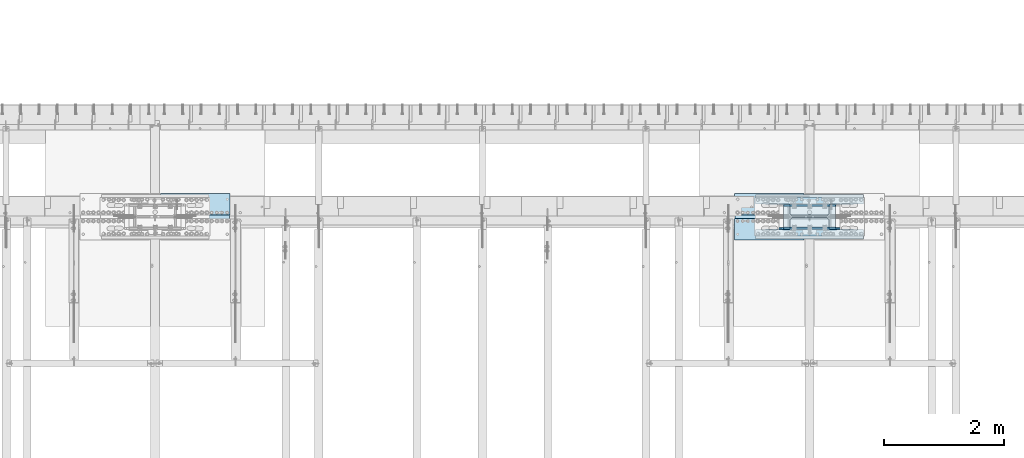
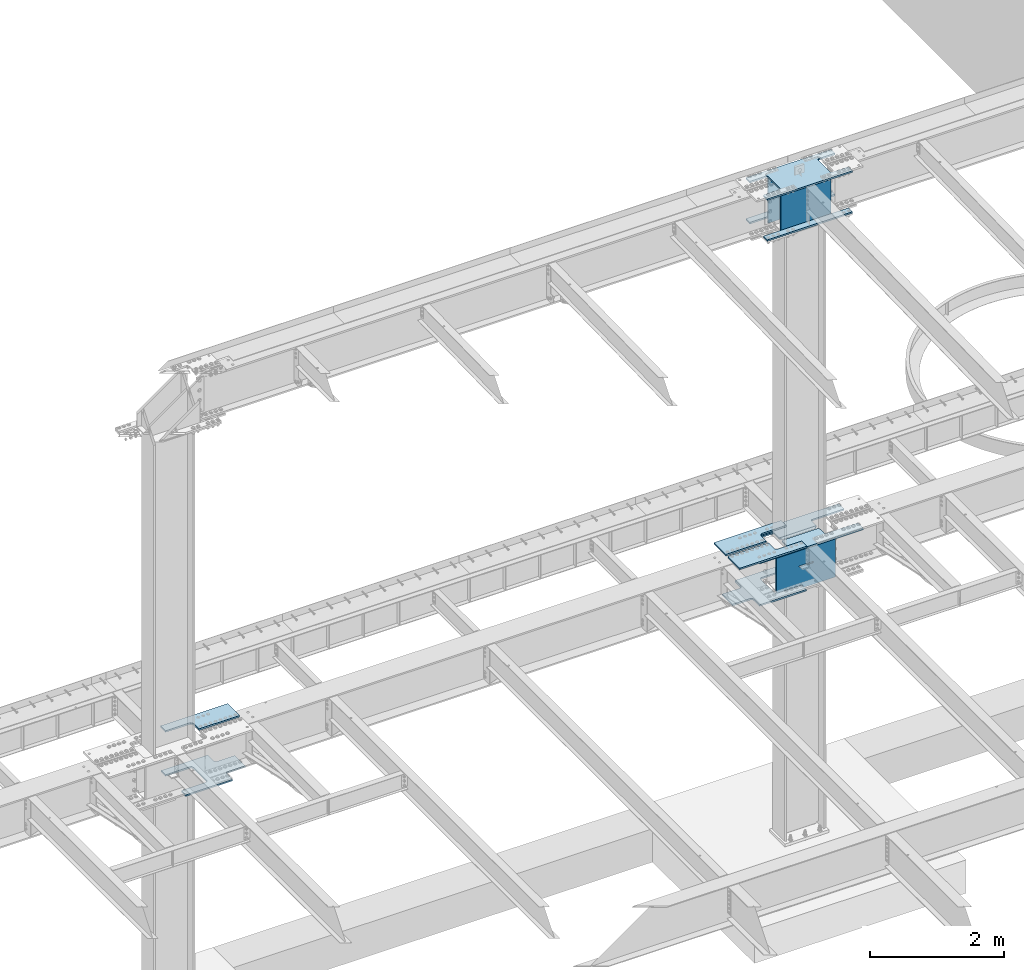
# One storey, part 1421 of 1763: 13 plates, 6 elements without a shape of their own.
"""IFC2X3 building model written with IfcOpenShell, lengths in millimetres."""

import ifcopenshell
import ifcopenshell.guid

model = None  # the IFC model being written
_history = None  # IfcOwnerHistory: only IFC2X3 demands one
_inside = {}  # id of a spatial element -> (the spatial element, [elements in it])
_under = {}  # id of a project, library or spatial element -> (it, [spatial elements below it])
_declared = {}  # id of a project -> (the project, [libraries it declares])
_typed = {}  # id of a type object -> (the type object, [elements of that type])
_made_of = {}  # id of a material, layer set ... -> (it, [elements and type objects made of it])


def new_model(schema):
    """Start an empty IFC model of exactly this schema.

    Asked for "IFC4X3", IfcOpenShell would pick the latest addendum, in which some entities
    have other attributes; the version numbers below select the first issue.
    IFC2X3 requires an IfcOwnerHistory on every rooted entity: one is made here for all.
    """
    global model, _history
    if schema == "IFC4X3":
        model = ifcopenshell.file(schema_version=(4, 3, 0, 0))
    else:
        model = ifcopenshell.file(schema=schema)
    _inside.clear()
    _under.clear()
    _declared.clear()
    _typed.clear()
    _made_of.clear()
    _history = None
    if model.schema == "IFC2X3":
        org = make("IfcOrganization", Name="unknown")
        user = make(
            "IfcPersonAndOrganization",
            ThePerson=make("IfcPerson", FamilyName="unknown"),
            TheOrganization=org,
        )
        app = make(
            "IfcApplication",
            ApplicationDeveloper=org,
            Version="unknown",
            ApplicationFullName="unknown",
            ApplicationIdentifier="unknown",
        )
        _history = make(
            "IfcOwnerHistory",
            OwningUser=user,
            OwningApplication=app,
            ChangeAction="ADDED",
            CreationDate=0,
        )
    return model


def make(cls, **values):
    """One entity of the class cls with the attributes given. An attribute that is None is left unset."""
    return model.create_entity(
        cls, **{name: value for name, value in values.items() if value is not None}
    )


def rooted(cls, **values):
    """An entity with a GlobalId (a new one), such as an element, a storey or a relation."""
    return make(cls, GlobalId=ifcopenshell.guid.new(), OwnerHistory=_history, **values)


def si_unit(unit_type, name, prefix=None):
    """IfcSIUnit, for example si_unit("LENGTHUNIT", "METRE", prefix="MILLI")."""
    return make("IfcSIUnit", UnitType=unit_type, Prefix=prefix, Name=name)


def assignment(units):
    """IfcUnitAssignment: the units of a project."""
    return None if units is None else make("IfcUnitAssignment", Units=units)


def point(xyz):
    """IfcCartesianPoint."""
    return None if xyz is None else make("IfcCartesianPoint", Coordinates=xyz)


def direction(xyz):
    """IfcDirection."""
    return None if xyz is None else make("IfcDirection", DirectionRatios=xyz)


def frame(location, z_axis=None, x_axis=None):
    """IfcAxis2Placement3D, a coordinate frame: its origin and axes. An axis left out is left unset."""
    return make(
        "IfcAxis2Placement3D",
        Location=point(location),
        Axis=direction(z_axis),
        RefDirection=direction(x_axis),
    )


def origin_with_axes():
    """The frame at (0, 0, 0) with the z axis (0, 0, 1) and the x axis (1, 0, 0) written out."""
    return frame((0.0, 0.0, 0.0), z_axis=(0.0, 0.0, 1.0), x_axis=(1.0, 0.0, 0.0))


def place(relative_to, where):
    """IfcLocalPlacement: puts the frame where relative to a parent placement (None: the world)."""
    return make(
        "IfcLocalPlacement", PlacementRelTo=relative_to, RelativePlacement=where
    )


def context(
    kind, dimensions, precision=None, world=None, true_north=None, identifier=None
):
    """IfcGeometricRepresentationContext, for example the 3D "Model" context."""
    return make(
        "IfcGeometricRepresentationContext",
        ContextIdentifier=identifier,
        ContextType=kind,
        CoordinateSpaceDimension=dimensions,
        Precision=precision,
        WorldCoordinateSystem=world,
        TrueNorth=true_north,
    )


def subcontext(parent, identifier, kind, view, scale=None):
    """IfcGeometricRepresentationSubContext, for example "Body" below "Model"."""
    return make(
        "IfcGeometricRepresentationSubContext",
        ContextIdentifier=identifier,
        ContextType=kind,
        ParentContext=parent,
        TargetScale=scale,
        TargetView=view,
    )


def project(units=None, contexts=None):
    """IfcProject with its units and contexts."""
    return rooted(
        "IfcProject",
        Name="project",
        RepresentationContexts=contexts,
        UnitsInContext=assignment(units),
    )


def spatial(cls, under=None, at=None, **own):
    """A site, building, storey or space (cls), placed at a placement, below another one or the project."""
    s = rooted(cls, ObjectPlacement=at, **own)
    if under is not None:
        _under.setdefault(under.id(), (under, []))[1].append(s)
    return s


def faces_of(points, faces, orient=None, outer=None):
    """IfcFace entities. A face is a list of loops; a loop is a list of indices into points, from 0.

    orient and outer hold one flag for each loop. By default every Orientation is true, the
    first loop of a face is its IfcFaceOuterBound and the others are IfcFaceBound.
    """
    made = []
    for i, loops in enumerate(faces):
        bounds = []
        for j, loop in enumerate(loops):
            is_outer = j == 0 if outer is None else outer[i][j]
            bounds.append(
                make(
                    "IfcFaceOuterBound" if is_outer else "IfcFaceBound",
                    Bound=make("IfcPolyLoop", Polygon=[points[k] for k in loop]),
                    Orientation=True if orient is None else orient[i][j],
                )
            )
        made.append(make("IfcFace", Bounds=bounds))
    return made


def faceted_brep(points, faces, orient=None, outer=None, voids=None):
    """IfcFacetedBrep: a solid bounded by flat faces; with voids (closed shells), ...WithVoids."""
    shared = [point(p) for p in points]
    hull = make("IfcClosedShell", CfsFaces=faces_of(shared, faces, orient, outer))
    if voids is None:
        return make("IfcFacetedBrep", Outer=hull)
    return make(
        "IfcFacetedBrepWithVoids",
        Outer=hull,
        Voids=[
            make(cls, CfsFaces=faces_of(shared, fs, o, b)) for cls, fs, o, b in voids
        ],
    )


def shape(context_of_items, identifier, shape_type, items):
    """IfcShapeRepresentation: the items that make up one representation, for example the "Body"."""
    return make(
        "IfcShapeRepresentation",
        ContextOfItems=context_of_items,
        RepresentationIdentifier=identifier,
        RepresentationType=shape_type,
        Items=items,
    )


def material(Name=None, Category=None):
    """IfcMaterial."""
    return make("IfcMaterial", Name=Name, Category=Category)


def made_of(thing, what):
    """Note that an element or type object is made of a material, layer set ...; save() writes the relation."""
    if what is not None:
        _made_of.setdefault(what.id(), (what, []))[1].append(thing)
    return thing


def type_object(cls, material=None, **own):
    """A type object (cls), such as IfcWallType, which elements share."""
    return made_of(rooted(cls, **own), material)


def element(
    cls,
    number,
    at=None,
    inside=None,
    cuts=None,
    type_object=None,
    material=None,
    context=None,
    identifier="Body",
    shape_type=None,
    held_by="IfcProductDefinitionShape",
    body=None,
    shapes=None,
    **own,
):
    """One element of the class cls, such as IfcWall. Its Tag is "e" and its number.

    at: its placement. inside: the storey or other place that contains it. cuts: it is an
    opening in that element (IfcRelVoidsElement). A single representation is given by context,
    identifier, shape_type and body (its items); several are given by shapes. held_by: the class
    of the entity that holds the representations. save() writes the other relations.
    """
    e = rooted(cls, Tag="e%d" % number, ObjectPlacement=at, **own)
    if body is not None:
        shapes = [shape(context, identifier, shape_type, body)]
    if shapes is not None:
        e.Representation = make(held_by, Representations=shapes)
    if inside is not None:
        _inside.setdefault(inside.id(), (inside, []))[1].append(e)
    if cuts is not None:
        rooted(
            "IfcRelVoidsElement", RelatingBuildingElement=cuts, RelatedOpeningElement=e
        )
    if type_object is not None:
        _typed.setdefault(type_object.id(), (type_object, []))[1].append(e)
    return made_of(e, material)


def aggregate(whole, parts):
    """IfcRelAggregates: a whole, such as a stair, and the parts it consists of."""
    return rooted("IfcRelAggregates", RelatingObject=whole, RelatedObjects=parts)


def save(model, path):
    """Write the relations noted so far, then the file.

    IfcRelAggregates (storeys below a building ...), IfcRelContainedInSpatialStructure (elements
    in a storey), IfcRelDefinesByType, IfcRelAssociatesMaterial and IfcRelDeclares: one each for
    every whole, place, type object, material and project.
    """
    for whole, parts in _under.values():
        aggregate(whole, parts)
    for where, things in _inside.values():
        rooted(
            "IfcRelContainedInSpatialStructure",
            RelatedElements=things,
            RelatingStructure=where,
        )
    for kind, things in _typed.values():
        rooted("IfcRelDefinesByType", RelatedObjects=things, RelatingType=kind)
    for what, things in _made_of.values():
        rooted("IfcRelAssociatesMaterial", RelatedObjects=things, RelatingMaterial=what)
    for by, libraries in _declared.values():
        rooted("IfcRelDeclares", RelatingContext=by, RelatedDefinitions=libraries)
    model.write(path)


model = new_model("IFC2X3")

# Units and contexts
model_context = context("Model", 3, precision=1e-05, world=origin_with_axes())
body_context = subcontext(model_context, "Body", "Model", "MODEL_VIEW")
ifc_project = project(units=[si_unit("LENGTHUNIT", "METRE", prefix="MILLI"), si_unit("AREAUNIT", "SQUARE_METRE"), si_unit("VOLUMEUNIT", "CUBIC_METRE"), si_unit("MASSUNIT", "GRAM", prefix="KILO"), si_unit("TIMEUNIT", "SECOND"), si_unit("PLANEANGLEUNIT", "RADIAN"), si_unit("SOLIDANGLEUNIT", "STERADIAN"), si_unit("THERMODYNAMICTEMPERATUREUNIT", "DEGREE_CELSIUS"), si_unit("LUMINOUSINTENSITYUNIT", "LUMEN")], contexts=[model_context])

# Site, building, storey
site_placement = place(None, origin_with_axes())
site = spatial("IfcSite", under=ifc_project, at=site_placement, CompositionType="ELEMENT")
building_placement = place(site_placement, origin_with_axes())
building = spatial("IfcBuilding", under=site, at=building_placement, Name="Undefined", CompositionType="ELEMENT")
storey_placement = place(building_placement, origin_with_axes())
storey = spatial("IfcBuildingStorey", under=building, at=storey_placement, Name="Undefined", CompositionType="ELEMENT", Elevation=0.0)

# Assembly, plates
assembly_1_placement = place(storey_placement, origin_with_axes())
assembly_1 = element("IfcElementAssembly", 1, at=assembly_1_placement, inside=storey, Name="COLUMN", AssemblyPlace="NOTDEFINED", PredefinedType="RIGID_FRAME")
ifc_material_1 = material(Name="STEEL/A572-50")
plate_type_1 = type_object("IfcPlateType", PredefinedType="NOTDEFINED")
plate_1_placement = place(assembly_1_placement, frame((-60697.4997736984, 52111.275, 5180.0125), z_axis=(-1.0, 0.0, 0.0), x_axis=(0.0, -1.0, 0.0)))
plate_1 = element("IfcPlate", 2, at=plate_1_placement, type_object=plate_type_1, material=ifc_material_1, Name="PLATE", context=body_context, shape_type="Brep", body=[
    faceted_brep([(174.62499427794, 14.2875000000004, 574.67504882811), (174.62499427794, -14.2875000000004, 574.67504882811), (38.0999984741429, -14.2875000000004, 574.675024414115), (38.0999984741429, 14.2875000000004, 574.67504882811), (184.345153314032, 14.2875000000004, 572.741588982935), (184.345153314032, -14.2875000000004, 572.741588982935), (192.58550625034, 14.2875000000004, 567.23556118198), (192.58550625034, -14.2875000000004, 567.23556118198), (198.091534051295, 14.2875000000004, 558.995208245673), (198.091534051295, -14.2875000000004, 558.995208245673), (200.02499389647, 14.2875000000004, 549.27504920958), (200.02499389647, -14.2875000000004, 549.27504920958), (200.02499389647, 14.2875000000004, 0.0), (200.02499389647, -14.2875000000004, 0.0), (358.774993896484, 14.2875000000004, 0.0), (358.774993896484, -14.2875000000004, 0.0), (358.774993896484, -14.2875000000004, 1793.875), (358.774993896484, 14.2875000000004, 1793.875), (200.024993896448, 14.2875000000004, 1793.875), (200.024993896448, -14.2875000000004, 1793.87502441408), (200.024993896448, 14.2875000000004, 1244.59997520449), (200.024993896448, -14.2875000000004, 1244.59997520449), (198.091534051273, 14.2875000000004, 1234.8798161684), (198.091534051273, -14.2875000000004, 1234.8798161684), (192.585506250318, 14.2875000000004, 1226.63946323209), (192.585506250318, -14.2875000000004, 1226.63946323209), (184.345153314011, 14.2875000000004, 1221.13343543113), (184.345153314011, -14.2875000000004, 1221.13343543113), (174.624994277918, 14.2875000000004, 1219.19997558596), (174.624994277918, -14.2875000000004, 1219.19997558596), (38.0999984740847, 14.2875000000067, 1219.19997558596), (38.0999984740847, -14.2875000000004, 1219.19997558593), (28.5750003814683, 14.2875000000067, 1209.67497749336), (0.0, -14.2875000000004, 1181.09997711187), (0.0, -14.2875000000004, 612.775022888178), (28.575000381461, 14.2875000000004, 584.200037155169)], [[[0, 1, 2, 3]], [[1, 0, 4, 5]], [[5, 4, 6, 7]], [[7, 6, 8, 9]], [[9, 8, 10, 11]], [[11, 10, 12, 13]], [[14, 15, 13, 12]], [[16, 15, 14, 17]], [[16, 17, 18, 19]], [[19, 18, 20, 21]], [[21, 20, 22, 23]], [[23, 22, 24, 25]], [[25, 24, 26, 27]], [[27, 26, 28, 29]], [[29, 28, 30, 31]], [[31, 30, 32, 33]], [[2, 1, 5, 7, 9, 11, 13, 15, 16, 19, 21, 23, 25, 27, 29, 31, 33, 34]], [[3, 2, 34, 35]], [[30, 28, 26, 24, 22, 20, 18, 17, 14, 12, 10, 8, 6, 4, 0, 3, 35, 32]], [[34, 33, 32, 35]]]),
])
plate_2_placement = place(assembly_1_placement, frame((-60697.4997736984, 52130.325, 5180.0125), z_axis=(-1.0, 0.0, 0.0), x_axis=(0.0, 1.0, 0.0)))
plate_2 = element("IfcPlate", 3, at=plate_2_placement, type_object=plate_type_1, material=ifc_material_1, Name="PLATE", context=body_context, shape_type="Brep", body=[
    faceted_brep([(174.62499427794, 14.2875000000004, 574.67504882811), (174.62499427794, -14.2875000000004, 574.67504882811), (38.0999984741429, -14.2875000000004, 574.675024414115), (38.0999984741429, 14.2875000000004, 574.67504882811), (184.345153314032, 14.2875000000004, 572.741588982935), (184.345153314032, -14.2875000000004, 572.741588982935), (192.58550625034, 14.2875000000004, 567.23556118198), (192.58550625034, -14.2875000000004, 567.23556118198), (198.091534051295, 14.2875000000004, 558.995208245673), (198.091534051295, -14.2875000000004, 558.995208245673), (200.02499389647, 14.2875000000004, 549.27504920958), (200.02499389647, -14.2875000000004, 549.27504920958), (200.02499389647, 14.2875000000004, 0.0), (200.02499389647, -14.2875000000004, 0.0), (358.774993896484, 14.2875000000004, 0.0), (358.774993896484, -14.2875000000004, 0.0), (358.774993896484, -14.2875000000004, 1793.875), (358.774993896484, 14.2875000000004, 1793.875), (200.024993896448, 14.2875000000004, 1793.875), (200.024993896448, -14.2875000000004, 1793.87502441408), (200.024993896448, 14.2875000000004, 1244.59997520449), (200.024993896448, -14.2875000000004, 1244.59997520449), (198.091534051273, 14.2875000000004, 1234.8798161684), (198.091534051273, -14.2875000000004, 1234.8798161684), (192.585506250318, 14.2875000000004, 1226.63946323209), (192.585506250318, -14.2875000000004, 1226.63946323209), (184.345153314011, 14.2875000000004, 1221.13343543113), (184.345153314011, -14.2875000000004, 1221.13343543113), (174.624994277918, 14.2875000000004, 1219.19997558596), (174.624994277918, -14.2875000000004, 1219.19997558596), (38.0999984740847, 14.2875000000067, 1219.19997558596), (38.0999984740847, -14.2875000000004, 1219.19997558593), (28.5750000000116, -14.2875000000067, 1209.67497711188), (28.5750000000044, -14.2875000000004, 584.200022888232), (0.0, 14.2875000000004, 612.775022888178), (0.0, 14.2875000000004, 1181.09997711187)], [[[0, 1, 2, 3]], [[1, 0, 4, 5]], [[5, 4, 6, 7]], [[7, 6, 8, 9]], [[9, 8, 10, 11]], [[11, 10, 12, 13]], [[14, 15, 13, 12]], [[16, 15, 14, 17]], [[16, 17, 18, 19]], [[19, 18, 20, 21]], [[21, 20, 22, 23]], [[23, 22, 24, 25]], [[25, 24, 26, 27]], [[27, 26, 28, 29]], [[29, 28, 30, 31]], [[2, 1, 5, 7, 9, 11, 13, 15, 16, 19, 21, 23, 25, 27, 29, 31, 32, 33]], [[3, 2, 33, 34]], [[30, 28, 26, 24, 22, 20, 18, 17, 14, 12, 10, 8, 6, 4, 0, 3, 34, 35]], [[31, 30, 35, 32]], [[34, 33, 32, 35]]]),
])

# Assembly, plate
assembly_2_placement = place(storey_placement, origin_with_axes())
assembly_2 = element("IfcElementAssembly", 4, at=assembly_2_placement, inside=storey, Name="TOP PLATE", AssemblyPlace="NOTDEFINED", PredefinedType="RIGID_FRAME")
plate_3_placement = place(assembly_2_placement, frame((-71943.3497736984, 52149.375, 5208.5875), z_axis=(0.0, 1.0, 0.0), x_axis=(1.0, 0.0, 0.0)))
plate_3 = element("IfcPlate", 5, at=plate_3_placement, type_object=plate_type_1, material=ifc_material_1, Name="TOP PLATE", context=body_context, shape_type="Brep", body=[
    faceted_brep([(0.0, -14.2875000000058, 0.0), (0.0, -14.2875000000004, 161.924999237061), (0.0, 14.2875000000004, 161.924999237061), (0.0, 14.2875000000058, 0.0), (-3.38355483794294, -14.2875000000004, 178.935278097655), (-3.38355483794294, 14.2875000000004, 178.935278097655), (-13.0191037997138, -14.2875000000004, 193.355896200279), (-13.0191037997138, 14.2875000000004, 193.355896200279), (-27.4397219023522, -14.2875000000004, 202.99144516205), (-27.4397219023522, 14.2875000000004, 202.99144516205), (-44.4500007629395, -14.2875000000004, 206.375), (-44.4500007629395, 14.2875000000004, 206.375), (-457.200012207031, -14.2875000000004, 206.375), (-457.200012207031, 14.2875000000004, 206.375), (-457.200012207031, -14.2875000000004, 358.774993896484), (-457.200012207031, 14.2875000000004, 358.774993896484), (701.674987792969, -14.2875000000004, 358.774993896484), (701.674987792969, 14.2875000000004, 358.774993896484), (701.674987792969, -14.2875000000004, 0.0), (701.674987792969, 14.2875000000004, 0.0)], [[[0, 1, 2, 3]], [[1, 4, 5, 2]], [[4, 6, 7, 5]], [[6, 8, 9, 7]], [[8, 10, 11, 9]], [[10, 12, 13, 11]], [[12, 14, 15, 13]], [[14, 16, 17, 15]], [[16, 18, 19, 17]], [[18, 0, 3, 19]], [[5, 7, 9, 11, 13, 15, 17, 19, 3, 2]], [[18, 16, 14, 12, 10, 8, 6, 4, 1, 0]]]),
])
aggregate(assembly_2, [plate_3])

assembly_3_placement = place(storey_placement, origin_with_axes())
assembly_3 = element("IfcElementAssembly", 6, at=assembly_3_placement, inside=storey, Name="TOP PLATE", AssemblyPlace="NOTDEFINED", PredefinedType="RIGID_FRAME")
plate_4_placement = place(assembly_3_placement, frame((-62843.7997736984, 52149.375, 5208.5875), z_axis=(0.0, 1.0, 0.0), x_axis=(1.0, 0.0, 0.0)))
plate_4 = element("IfcPlate", 7, at=plate_4_placement, type_object=plate_type_1, material=ifc_material_1, Name="TOP PLATE", context=body_context, shape_type="Brep", body=[
    faceted_brep([(0.0, -14.2875000000058, 0.0), (0.0, -14.2875000000004, 358.774993896484), (0.0, 14.2875000000004, 358.774993896484), (0.0, 14.2875000000058, 0.0), (1158.875, -14.2875000000004, 358.774993896484), (1158.875, 14.2875000000004, 358.774993896484), (1158.875, -14.2875000000004, 206.375), (1158.875, 14.2875000000004, 206.375), (746.124988555908, -14.2875000000004, 206.375), (746.124988555908, 14.2875000000004, 206.375), (729.114709695321, -14.2875000000004, 202.99144516205), (729.114709695321, 14.2875000000004, 202.99144516205), (714.694091592683, -14.2875000000004, 193.355896200279), (714.694091592683, 14.2875000000004, 193.355896200279), (705.058542630912, -14.2875000000004, 178.935278097655), (705.058542630912, 14.2875000000004, 178.935278097655), (701.674987792969, -14.2875000000004, 161.924999237061), (701.674987792969, 14.2875000000004, 161.924999237061), (701.674987792969, -14.2875000000004, 0.0), (701.674987792969, 14.2875000000004, 0.0)], [[[0, 1, 2, 3]], [[1, 4, 5, 2]], [[4, 6, 7, 5]], [[6, 8, 9, 7]], [[8, 10, 11, 9]], [[10, 12, 13, 11]], [[12, 14, 15, 13]], [[14, 16, 17, 15]], [[16, 18, 19, 17]], [[18, 0, 3, 19]], [[5, 7, 9, 11, 13, 15, 17, 19, 3, 2]], [[18, 16, 14, 12, 10, 8, 6, 4, 1, 0]]]),
])
aggregate(assembly_3, [plate_4])

assembly_4_placement = place(storey_placement, origin_with_axes())
assembly_4 = element("IfcElementAssembly", 8, at=assembly_4_placement, inside=storey, Name="TOP PLATE", AssemblyPlace="NOTDEFINED", PredefinedType="RIGID_FRAME")
plate_5_placement = place(assembly_4_placement, frame((-62142.1247736983, 52092.225, 5208.5875), z_axis=(0.0, -1.0, 0.0), x_axis=(-1.0, 0.0, 0.0)))
plate_5 = element("IfcPlate", 9, at=plate_5_placement, type_object=plate_type_1, material=ifc_material_1, Name="TOP PLATE", context=body_context, shape_type="Brep", body=[
    faceted_brep([(0.0, -14.2875000000058, 0.0), (0.0, -14.2875000000004, 161.924999237061), (0.0, 14.2875000000004, 161.924999237061), (0.0, 14.2875000000058, 0.0), (-3.38355483794294, -14.2875000000004, 178.935278097655), (-3.38355483794294, 14.2875000000004, 178.935278097655), (-13.0191037997138, -14.2875000000004, 193.355896200279), (-13.0191037997138, 14.2875000000004, 193.355896200279), (-27.4397219023522, -14.2875000000004, 202.99144516205), (-27.4397219023522, 14.2875000000004, 202.99144516205), (-44.4500007629395, -14.2875000000004, 206.375), (-44.4500007629395, 14.2875000000004, 206.375), (-457.200012207031, -14.2875000000004, 206.375), (-457.200012207031, 14.2875000000004, 206.375), (-457.200012207031, -14.2875000000004, 358.774993896484), (-457.200012207031, 14.2875000000004, 358.774993896484), (701.674987792969, -14.2875000000004, 358.774993896484), (701.674987792969, 14.2875000000004, 358.774993896484), (701.674987792969, -14.2875000000004, 0.0), (701.674987792969, 14.2875000000004, 0.0)], [[[0, 1, 2, 3]], [[1, 4, 5, 2]], [[4, 6, 7, 5]], [[6, 8, 9, 7]], [[8, 10, 11, 9]], [[10, 12, 13, 11]], [[12, 14, 15, 13]], [[14, 16, 17, 15]], [[16, 18, 19, 17]], [[18, 0, 3, 19]], [[5, 7, 9, 11, 13, 15, 17, 19, 3, 2]], [[18, 16, 14, 12, 10, 8, 6, 4, 1, 0]]]),
])
aggregate(assembly_4, [plate_5])

# Plate
plate_type_2 = type_object("IfcPlateType", PredefinedType="NOTDEFINED")
plate_6_placement = place(assembly_1_placement, frame((-62329.4497736984, 52441.4750002128, 11733.2124917654), z_axis=(1.0, 0.0, 0.0), x_axis=(0.0, -1.0, 0.0)))
plate_6 = element("IfcPlate", 10, at=plate_6_placement, type_object=plate_type_2, material=ifc_material_1, Name="PLATE", context=body_context, shape_type="Brep", body=[
    faceted_brep([(117.474998474121, -14.2875000000004, 1470.02502441406), (117.475000194951, -14.2875000000004, 1193.7999996006), (117.475000166465, 14.2875000000004, 1193.79999957211), (117.474998474121, 14.2875000000004, 1470.02502441406), (119.40846004527, -14.2875000000004, 1184.07984057001), (119.408460016784, 14.2875000000004, 1184.07984054153), (124.914487847418, -14.2875000000004, 1175.83948763979), (124.914487818933, 14.2875000000004, 1175.8394876113), (133.154840781528, -14.2875000000004, 1170.33345984345), (133.154840753043, 14.2875000000004, 1170.33345981497), (142.874999813481, -14.2875000000004, 1168.39999999999), (142.874999784995, 14.2875000000004, 1168.3999999715), (498.474994490825, -14.2875000000004, 1168.39999999997), (498.47499446234, 14.2875000000004, 1168.39999997149), (508.195153526918, -14.2875000000004, 1170.33345984515), (508.195153498433, 14.2875000000004, 1170.33345981667), (516.435506463225, -14.2875000000004, 1175.83948764611), (516.43550643474, 14.2875000000004, 1175.83948761762), (521.941534264181, -14.2875000000004, 1184.07984058242), (521.941534235695, 14.2875000000004, 1184.07984055393), (523.874994109356, -14.2875000000004, 1193.7999996185), (523.874994080878, 14.2875000000004, 1193.79999959002), (523.874994109356, -14.2875000000004, 1470.02503051757), (523.874994080878, 14.2875000000004, 1470.02502441406), (0.0, -14.2875000000058, 0.0), (-2.91038304567337e-11, -14.2875000000004, 1470.02502441406), (-2.91038304567337e-11, 14.2875000000004, 1470.02502441406), (0.0, 14.2875000000058, 0.0), (117.474975585938, -14.2875000000004, 0.0), (117.474975585938, 14.2875000000004, 0.0), (117.475000167673, 14.2875000000004, 276.224976013829), (117.475000196158, -14.2875000000004, 276.224975985344), (119.408460017992, 14.2875000000004, 285.945135044414), (119.408460046478, -14.2875000000004, 285.945135015929), (124.91448782014, 14.2875000000004, 294.185487974639), (124.914487848626, -14.2875000000004, 294.185487946153), (133.154840754258, 14.2875000000004, 299.691515770974), (133.154840782736, -14.2875000000004, 299.691515742488), (142.874999786203, 14.2875000000004, 301.624975614432), (142.874999814689, -14.2875000000004, 301.624975585954), (498.474994463555, 14.2875000000004, 301.624975614432), (498.474994492033, -14.2875000000004, 301.624975585954), (508.195153499641, 14.2875000000004, 299.691515769257), (508.195153528126, -14.2875000000004, 299.691515740778), (516.435506435948, 14.2875000000004, 294.185487968301), (516.435506464433, -14.2875000000004, 294.185487939816), (521.941534236903, 14.2875000000004, 285.945135031994), (521.941534265388, -14.2875000000004, 285.945135003509), (523.874994082085, 14.2875000000004, 276.224975995901), (523.874994110563, -14.2875000000004, 276.224975967423), (523.874994082085, 14.2875000000004, 1.45519152283669e-11), (523.874994110563, -14.2875000000004, 1.45519152283669e-11), (641.349975585938, 14.2875000000004, 1.45519152283669e-11), (641.349975585938, -14.2875000000004, 1.45519152283669e-11), (641.349975585938, -14.2875000000004, 1470.02502441406), (641.349975585938, 14.2875000000004, 1470.02502441406)], [[[0, 1, 2, 3]], [[4, 5, 2, 1]], [[6, 7, 5, 4]], [[8, 9, 7, 6]], [[10, 11, 9, 8]], [[12, 13, 11, 10]], [[14, 15, 13, 12]], [[16, 17, 15, 14]], [[18, 19, 17, 16]], [[20, 21, 19, 18]], [[22, 23, 21, 20]], [[24, 25, 26, 27]], [[28, 24, 27, 29]], [[28, 29, 30, 31]], [[31, 30, 32, 33]], [[33, 32, 34, 35]], [[35, 34, 36, 37]], [[37, 36, 38, 39]], [[39, 38, 40, 41]], [[41, 40, 42, 43]], [[43, 42, 44, 45]], [[45, 44, 46, 47]], [[47, 46, 48, 49]], [[49, 48, 50, 51]], [[52, 53, 51, 50]], [[54, 53, 52, 55]], [[18, 16, 14, 12, 10, 8, 6, 4, 1, 0, 25, 24, 28, 31, 33, 35, 37, 39, 41, 43, 45, 47, 49, 51, 53, 54, 22, 20]], [[25, 0, 3, 26]], [[55, 52, 50, 48, 46, 44, 42, 40, 38, 36, 34, 32, 30, 29, 27, 26, 3, 2, 5, 7, 9, 11, 13, 15, 17, 19, 21, 23]], [[54, 55, 23, 22]]]),
])

ifc_material_2 = material(Name="STEEL/A36")
plate_type_3 = type_object("IfcPlateType", PredefinedType="NOTDEFINED")
plate_7_placement = place(assembly_1_placement, frame((-62329.4497736984, 52324.0000017387, 10983.9124917654), z_axis=(0.0, 1.0, 0.0), x_axis=(1.0, 0.0, 0.0)))
plate_7 = element("IfcPlate", 11, at=plate_7_placement, type_object=plate_type_3, material=ifc_material_2, Name="PLATE", context=body_context, shape_type="Brep", body=[
    faceted_brep([(0.0, -14.2875000000058, 0.0), (0.0, -14.2875000000004, 117.474998474121), (0.0, 14.2875000000004, 117.474998474121), (0.0, 14.2875000000058, 0.0), (1470.02502441406, -14.2875000000004, 117.474998474121), (1470.02502441406, 14.2875000000004, 117.474998474121), (1470.02502441406, -14.2875000000004, 7.27595761418343e-12), (1470.02502441406, 14.2875000000004, 7.27595761418343e-12)], [[[0, 1, 2, 3]], [[1, 4, 5, 2]], [[4, 6, 7, 5]], [[6, 0, 3, 7]], [[5, 7, 3, 2]], [[6, 4, 1, 0]]]),
])

plate_8_placement = place(assembly_1_placement, frame((-62329.4497736984, 51917.6000002128, 10983.9124917654), z_axis=(1.0, 0.0, 0.0), x_axis=(0.0, -1.0, 0.0)))
plate_8 = element("IfcPlate", 12, at=plate_8_placement, type_object=plate_type_3, material=ifc_material_2, Name="PLATE", context=body_context, shape_type="Brep", body=[
    faceted_brep([(0.0, -14.2875000000058, 0.0), (-2.91038304567337e-11, -14.2875000000004, 1470.02502441406), (-2.91038304567337e-11, 14.2875000000004, 1470.02502441406), (0.0, 14.2875000000058, 0.0), (117.474998474121, -14.2875000000004, 1470.02502441406), (117.474998474121, 14.2875000000004, 1470.02502441406), (117.474975585938, -14.2875000000004, 0.0), (117.474975585938, 14.2875000000004, 0.0)], [[[0, 1, 2, 3]], [[1, 4, 5, 2]], [[4, 6, 7, 5]], [[6, 0, 3, 7]], [[5, 7, 3, 2]], [[6, 4, 1, 0]]]),
])

plate_type_4 = type_object("IfcPlateType", PredefinedType="NOTDEFINED")
plate_9_placement = place(assembly_1_placement, frame((-61161.0497736698, 52311.3, 11718.9249917654), z_axis=(0.0, 0.0, -1.0), x_axis=(-1.0, 0.0, 0.0)))
plate_9 = element("IfcPlate", 13, at=plate_9_placement, type_object=plate_type_4, material=ifc_material_1, Name="COVER PLATE", context=body_context, shape_type="Brep", body=[
    faceted_brep([(0.0, -12.6999999999971, -1.81898940354586e-12), (2.85799615085125e-08, -12.6999999999971, 825.5), (2.85799615085125e-08, 12.6999999999971, 825.5), (0.0, 12.6999999999971, -1.81898940354586e-12), (866.775024414062, -12.6999999999971, 825.5), (866.775024414062, 12.6999999999971, 825.5), (866.775024414062, -12.6999999999971, 0.0), (866.775024414062, 12.6999999999971, 0.0)], [[[0, 1, 2, 3]], [[1, 4, 5, 2]], [[4, 6, 7, 5]], [[6, 0, 3, 7]], [[5, 7, 3, 2]], [[6, 4, 1, 0]]]),
])

plate_10_placement = place(assembly_1_placement, frame((-61161.0497736698, 51930.3, 11718.9249917654), z_axis=(0.0, 0.0, -1.0), x_axis=(-1.0, 0.0, 0.0)))
plate_10 = element("IfcPlate", 14, at=plate_10_placement, type_object=plate_type_4, material=ifc_material_1, Name="COVER PLATE", context=body_context, shape_type="Brep", body=[
    faceted_brep([(0.0, -12.6999999999971, -1.81898940354586e-12), (2.85799615085125e-08, -12.6999999999971, 825.5), (2.85799615085125e-08, 12.6999999999971, 825.5), (0.0, 12.6999999999971, -1.81898940354586e-12), (866.775024414062, -12.6999999999971, 825.5), (866.775024414062, 12.6999999999971, 825.5), (866.775024414062, -12.6999999999971, 0.0), (866.775024414062, 12.6999999999971, 0.0)], [[[0, 1, 2, 3]], [[1, 4, 5, 2]], [[4, 6, 7, 5]], [[6, 0, 3, 7]], [[5, 7, 3, 2]], [[6, 4, 1, 0]]]),
])

# Assembly, plate
assembly_5_placement = place(storey_placement, origin_with_axes())
assembly_5 = element("IfcElementAssembly", 15, at=assembly_5_placement, inside=storey, Name="PLATE", AssemblyPlace="NOTDEFINED", PredefinedType="RIGID_FRAME")
plate_type_5 = type_object("IfcPlateType", PredefinedType="NOTDEFINED")
plate_11_placement = place(assembly_5_placement, frame((-72400.5497736984, 51752.5, 4405.3125), z_axis=(0.0, 1.0, 0.0), x_axis=(1.0, 0.0, 0.0)))
plate_11 = element("IfcPlate", 16, at=plate_11_placement, type_object=plate_type_5, material=ifc_material_1, Name="PLATE", context=body_context, shape_type="Brep", body=[
    faceted_brep([(0.0, -14.2875000000058, 0.0), (0.0, -14.2875000000004, 133.350006103516), (0.0, 14.2875000000004, 133.350006103516), (0.0, 14.2875000000058, 0.0), (417.512512207031, -14.2875000000004, 133.350006103516), (417.512512207031, 14.2875000000004, 133.350006103516), (429.776624171282, -14.2875000000004, 135.292450613051), (429.776624171282, 14.2875000000004, 135.292450613051), (440.840239407393, -14.2875000000004, 140.929644139258), (440.840239407393, 14.2875000000004, 140.929644139258), (449.620374171282, -14.2875000000004, 149.709778903161), (449.620374171282, 14.2875000000004, 149.709778903161), (455.257567697496, -14.2875000000004, 160.773394139258), (455.257567697496, 14.2875000000004, 160.773394139258), (457.200012207031, -14.2875000000004, 173.037506103516), (457.200012207031, 14.2875000000004, 173.037506103516), (457.200012207031, -14.2875000000004, 563.5625), (457.200012207031, 14.2875000000004, 563.5625), (455.257567697496, -14.2875000000004, 575.826611964258), (455.257567697496, 14.2875000000004, 575.826611964258), (449.620374171282, -14.2875000000004, 586.890227200354), (449.620374171282, 14.2875000000004, 586.890227200354), (440.840239407393, -14.2875000000004, 595.670361964258), (440.840239407393, 14.2875000000004, 595.670361964258), (429.776624171282, -14.2875000000004, 601.307555490464), (429.776624171282, 14.2875000000004, 601.307555490464), (417.512512207031, -14.2875000000004, 603.25), (417.512512207031, 14.2875000000004, 603.25), (0.0, -14.2875000000004, 603.25), (0.0, 14.2875000000004, 603.25), (0.0, -14.2875000000004, 736.599975585938), (0.0, 14.2875000000004, 736.599975585938), (806.450012207031, -14.2875000000004, 736.599975585938), (806.450012207031, 14.2875000000004, 736.599975585938), (806.450012207031, -14.2875000000004, 563.5625), (806.450012207031, 14.2875000000004, 563.5625), (808.392456716567, -14.2875000000004, 551.298388035742), (808.392456716567, 14.2875000000004, 551.298388035742), (814.029650242781, -14.2875000000004, 540.234772799646), (814.029650242781, 14.2875000000004, 540.234772799646), (822.80978500667, -14.2875000000004, 531.454638035742), (822.80978500667, 14.2875000000004, 531.454638035742), (833.873400242781, -14.2875000000004, 525.817444509536), (833.873400242781, 14.2875000000004, 525.817444509536), (846.137512207031, -14.2875000000004, 523.875), (846.137512207031, 14.2875000000004, 523.875), (1149.34997558594, -14.2875000000004, 523.875), (1149.34997558594, 14.2875000000004, 523.875), (1149.34997558594, -14.2875000000004, 212.725006103516), (1149.34997558594, 14.2875000000004, 212.725006103516), (846.137512207031, -14.2875000000004, 212.725006103516), (846.137512207031, 14.2875000000004, 212.725006103516), (833.873400242781, -14.2875000000004, 210.78256159398), (833.873400242781, 14.2875000000004, 210.78256159398), (822.80978500667, -14.2875000000004, 205.145368067773), (822.80978500667, 14.2875000000004, 205.145368067773), (814.029650242781, -14.2875000000004, 196.36523330387), (814.029650242781, 14.2875000000004, 196.36523330387), (808.392456716567, -14.2875000000004, 185.301618067773), (808.392456716567, 14.2875000000004, 185.301618067773), (806.450012207031, -14.2875000000004, 173.037506103516), (806.450012207031, 14.2875000000004, 173.037506103516), (806.450012207031, -14.2875000000004, 0.0), (806.450012207031, 14.2875000000004, 0.0)], [[[0, 1, 2, 3]], [[1, 4, 5, 2]], [[4, 6, 7, 5]], [[6, 8, 9, 7]], [[8, 10, 11, 9]], [[10, 12, 13, 11]], [[12, 14, 15, 13]], [[14, 16, 17, 15]], [[16, 18, 19, 17]], [[18, 20, 21, 19]], [[20, 22, 23, 21]], [[22, 24, 25, 23]], [[24, 26, 27, 25]], [[26, 28, 29, 27]], [[28, 30, 31, 29]], [[30, 32, 33, 31]], [[32, 34, 35, 33]], [[34, 36, 37, 35]], [[36, 38, 39, 37]], [[38, 40, 41, 39]], [[40, 42, 43, 41]], [[42, 44, 45, 43]], [[44, 46, 47, 45]], [[46, 48, 49, 47]], [[48, 50, 51, 49]], [[50, 52, 53, 51]], [[52, 54, 55, 53]], [[54, 56, 57, 55]], [[56, 58, 59, 57]], [[58, 60, 61, 59]], [[60, 62, 63, 61]], [[62, 0, 3, 63]], [[5, 7, 9, 11, 13, 15, 17, 19, 21, 23, 25, 27, 29, 31, 33, 35, 37, 39, 41, 43, 45, 47, 49, 51, 53, 55, 57, 59, 61, 63, 3, 2]], [[62, 60, 58, 56, 54, 52, 50, 48, 46, 44, 42, 40, 38, 36, 34, 32, 30, 28, 26, 24, 22, 20, 18, 16, 14, 12, 10, 8, 6, 4, 1, 0]]]),
])
aggregate(assembly_5, [plate_11])

assembly_6_placement = place(storey_placement, origin_with_axes())
assembly_6 = element("IfcElementAssembly", 17, at=assembly_6_placement, inside=storey, Name="PLATE", AssemblyPlace="NOTDEFINED", PredefinedType="RIGID_FRAME")
plate_12_placement = place(assembly_6_placement, frame((-61684.9247736984, 52489.1, 4405.3125), z_axis=(0.0, -1.0, 0.0), x_axis=(-1.0, 0.0, 0.0)))
plate_12 = element("IfcPlate", 18, at=plate_12_placement, type_object=plate_type_5, material=ifc_material_1, Name="PLATE", context=body_context, shape_type="Brep", body=[
    faceted_brep([(0.0, -14.2875000000058, 0.0), (0.0, -14.2875000000004, 133.350006103516), (0.0, 14.2875000000004, 133.350006103516), (0.0, 14.2875000000058, 0.0), (417.512512207031, -14.2875000000004, 133.350006103516), (417.512512207031, 14.2875000000004, 133.350006103516), (429.776624171282, -14.2875000000004, 135.292450613051), (429.776624171282, 14.2875000000004, 135.292450613051), (440.840239407393, -14.2875000000004, 140.929644139258), (440.840239407393, 14.2875000000004, 140.929644139258), (449.620374171282, -14.2875000000004, 149.709778903161), (449.620374171282, 14.2875000000004, 149.709778903161), (455.257567697496, -14.2875000000004, 160.773394139258), (455.257567697496, 14.2875000000004, 160.773394139258), (457.200012207031, -14.2875000000004, 173.037506103516), (457.200012207031, 14.2875000000004, 173.037506103516), (457.200012207031, -14.2875000000004, 563.5625), (457.200012207031, 14.2875000000004, 563.5625), (455.257567697496, -14.2875000000004, 575.826611964258), (455.257567697496, 14.2875000000004, 575.826611964258), (449.620374171282, -14.2875000000004, 586.890227200354), (449.620374171282, 14.2875000000004, 586.890227200354), (440.840239407393, -14.2875000000004, 595.670361964258), (440.840239407393, 14.2875000000004, 595.670361964258), (429.776624171282, -14.2875000000004, 601.307555490464), (429.776624171282, 14.2875000000004, 601.307555490464), (417.512512207031, -14.2875000000004, 603.25), (417.512512207031, 14.2875000000004, 603.25), (0.0, -14.2875000000004, 603.25), (0.0, 14.2875000000004, 603.25), (0.0, -14.2875000000004, 736.599975585938), (0.0, 14.2875000000004, 736.599975585938), (806.450012207031, -14.2875000000004, 736.599975585938), (806.450012207031, 14.2875000000004, 736.599975585938), (806.450012207031, -14.2875000000004, 563.5625), (806.450012207031, 14.2875000000004, 563.5625), (808.392456716567, -14.2875000000004, 551.298388035742), (808.392456716567, 14.2875000000004, 551.298388035742), (814.029650242781, -14.2875000000004, 540.234772799646), (814.029650242781, 14.2875000000004, 540.234772799646), (822.80978500667, -14.2875000000004, 531.454638035742), (822.80978500667, 14.2875000000004, 531.454638035742), (833.873400242781, -14.2875000000004, 525.817444509536), (833.873400242781, 14.2875000000004, 525.817444509536), (846.137512207031, -14.2875000000004, 523.875), (846.137512207031, 14.2875000000004, 523.875), (1149.34997558594, -14.2875000000004, 523.875), (1149.34997558594, 14.2875000000004, 523.875), (1149.34997558594, -14.2875000000004, 212.725006103516), (1149.34997558594, 14.2875000000004, 212.725006103516), (846.137512207031, -14.2875000000004, 212.725006103516), (846.137512207031, 14.2875000000004, 212.725006103516), (833.873400242781, -14.2875000000004, 210.78256159398), (833.873400242781, 14.2875000000004, 210.78256159398), (822.80978500667, -14.2875000000004, 205.145368067773), (822.80978500667, 14.2875000000004, 205.145368067773), (814.029650242781, -14.2875000000004, 196.36523330387), (814.029650242781, 14.2875000000004, 196.36523330387), (808.392456716567, -14.2875000000004, 185.301618067773), (808.392456716567, 14.2875000000004, 185.301618067773), (806.450012207031, -14.2875000000004, 173.037506103516), (806.450012207031, 14.2875000000004, 173.037506103516), (806.450012207031, -14.2875000000004, 0.0), (806.450012207031, 14.2875000000004, 0.0)], [[[0, 1, 2, 3]], [[1, 4, 5, 2]], [[4, 6, 7, 5]], [[6, 8, 9, 7]], [[8, 10, 11, 9]], [[10, 12, 13, 11]], [[12, 14, 15, 13]], [[14, 16, 17, 15]], [[16, 18, 19, 17]], [[18, 20, 21, 19]], [[20, 22, 23, 21]], [[22, 24, 25, 23]], [[24, 26, 27, 25]], [[26, 28, 29, 27]], [[28, 30, 31, 29]], [[30, 32, 33, 31]], [[32, 34, 35, 33]], [[34, 36, 37, 35]], [[36, 38, 39, 37]], [[38, 40, 41, 39]], [[40, 42, 43, 41]], [[42, 44, 45, 43]], [[44, 46, 47, 45]], [[46, 48, 49, 47]], [[48, 50, 51, 49]], [[50, 52, 53, 51]], [[52, 54, 55, 53]], [[54, 56, 57, 55]], [[56, 58, 59, 57]], [[58, 60, 61, 59]], [[60, 62, 63, 61]], [[62, 0, 3, 63]], [[5, 7, 9, 11, 13, 15, 17, 19, 21, 23, 25, 27, 29, 31, 33, 35, 37, 39, 41, 43, 45, 47, 49, 51, 53, 55, 57, 59, 61, 63, 3, 2]], [[62, 60, 58, 56, 54, 52, 50, 48, 46, 44, 42, 40, 38, 36, 34, 32, 30, 28, 26, 24, 22, 20, 18, 16, 14, 12, 10, 8, 6, 4, 1, 0]]]),
])
aggregate(assembly_6, [plate_12])

# Plate
plate_type_6 = type_object("IfcPlateType", PredefinedType="NOTDEFINED")
plate_13_placement = place(assembly_1_placement, frame((-62104.0247736984, 51927.125, 5165.725), z_axis=(0.0, 0.0, -1.0), x_axis=(1.0, 0.0, 0.0)))
plate_13 = element("IfcPlate", 19, at=plate_13_placement, type_object=plate_type_6, material=ifc_material_1, Name="COVER PLATE", context=body_context, shape_type="Brep", body=[
    faceted_brep([(984.249999237072, 15.8750000000218, 31.7499999999918), (984.249999237072, -15.875, 0.0), (796.9250236511, -15.875, 0.0), (796.9250236511, 15.8750000000073, 31.7499999999991), (984.249999237072, 15.875, 0.0), (34.9249992370751, 15.8750000000218, 31.7499999999918), (34.9249992370751, -15.875, 0.0), (34.9249992370751, 15.875, 0.0), (222.250023651097, 15.8750000000218, 31.7499999999918), (222.250023651097, -15.875, 0.0), (0.0, -15.875, 0.0), (0.0, 15.875, 0.0), (0.0, -15.875, 822.324951171875), (0.0, 15.875, 822.324951171875), (1019.17498779297, -15.875, 822.324951171875), (1019.17498779297, 15.875, 822.324951171875), (1019.17498779297, -15.875, 0.0), (1019.17498779297, 15.875, 0.0), (631.745205739557, 15.875, 423.782722524225), (628.140051213893, 15.875, 426.191609764667), (623.88748149875, 15.875, 427.037498474155), (395.287500190767, 15.875, 427.037498474155), (391.034930475624, 15.875, 426.191609764667), (387.42977594996, 15.875, 423.782722524225), (385.020888709521, 15.875, 420.177567998568), (384.175000000032, 15.875, 415.925000190768), (385.020888709521, 15.875, 411.67243047562), (387.42977594996, 15.875, 408.067275949962), (391.034930475624, 15.875, 405.65838870952), (395.287500190767, 15.875, 404.812500000033), (623.88748149875, 15.875, 404.812500000009), (628.140051213893, 15.875, 405.658388709496), (631.745205739557, 15.875, 408.067275949938), (634.154092979996, 15.875, 411.672430475595), (634.999981689485, 15.875, 415.92499828342), (634.154092979996, 15.875, 420.177567998568), (634.154092979996, -15.875, 420.177567998568), (634.999981689485, -15.875, 415.92499828342), (631.745205739557, -15.875, 423.782722524225), (628.140051213893, -15.875, 426.191609764667), (623.88748149875, -15.875, 427.037498474155), (395.287500190767, -15.875, 427.037498474155), (391.034930475624, -15.875, 426.191609764667), (387.42977594996, -15.875, 423.782722524225), (385.020888709521, -15.875, 420.177567998568), (384.175000000032, -15.875, 415.925000190768), (385.020888709521, -15.875, 411.67243047562), (387.42977594996, -15.875, 408.067275949962), (391.034930475624, -15.875, 405.65838870952), (395.287500190767, -15.875, 404.812500000033), (623.88748149875, -15.875, 404.812500000009), (628.140051213893, -15.875, 405.658388709496), (631.745205739557, -15.875, 408.067275949938), (634.154092979996, -15.875, 411.672430475595)], [[[0, 1, 2, 3]], [[4, 1, 0]], [[5, 6, 7]], [[8, 9, 6, 5]], [[10, 11, 7, 6]], [[10, 12, 13, 11]], [[12, 14, 15, 13]], [[14, 16, 17, 15]], [[17, 16, 1, 4]], [[8, 5, 7, 11, 13, 15, 17, 4, 0, 3], [18, 19, 20, 21, 22, 23, 24, 25, 26, 27, 28, 29, 30, 31, 32, 33, 34, 35]], [[36, 35, 34, 37]], [[38, 18, 35, 36]], [[39, 19, 18, 38]], [[40, 20, 19, 39]], [[41, 21, 20, 40]], [[42, 22, 21, 41]], [[43, 23, 22, 42]], [[44, 24, 23, 43]], [[45, 25, 24, 44]], [[46, 26, 25, 45]], [[47, 27, 26, 46]], [[48, 28, 27, 47]], [[49, 29, 28, 48]], [[50, 30, 29, 49]], [[51, 31, 30, 50]], [[52, 32, 31, 51]], [[53, 33, 32, 52]], [[37, 34, 33, 53]], [[16, 14, 12, 10, 6, 9, 2, 1], [52, 51, 50, 49, 48, 47, 46, 45, 44, 43, 42, 41, 40, 39, 38, 36, 37, 53]], [[3, 2, 9, 8]]]),
])

aggregate(assembly_1, [plate_1, plate_2, plate_6, plate_9, plate_10, plate_7, plate_8, plate_13])

save(model, "model.ifc")
